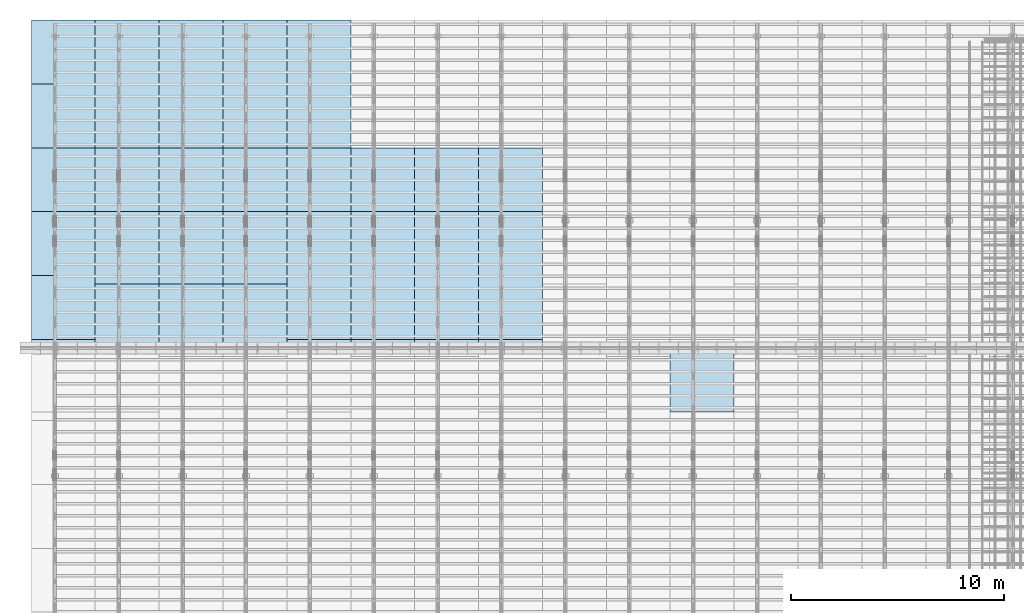
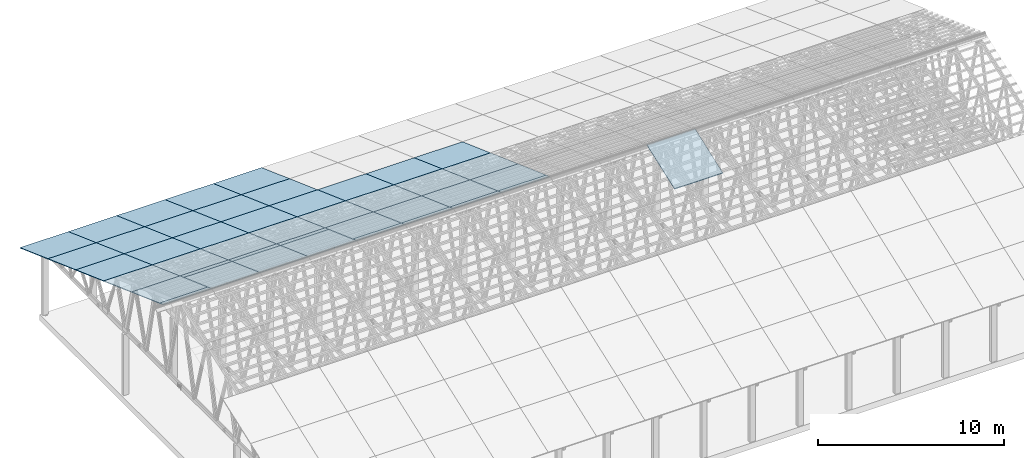
# One storey, part 7 of 189: 43 slabs, 43 elements without a shape of their own.
"""IFC2X3 building model written with IfcOpenShell, lengths in millimetres."""

from ifc_helpers import new_model, entity, si_unit, converted_unit, derived_unit, direction, frame, frame_2d, origin, place, context, subcontext, project, spatial, rectangle, extrude, material, layer, layer_set, element, aggregate, save


model = new_model("IFC2X3")

# Units and contexts
model_context = context("Model", 3, precision=0.01, world=origin(), true_north=direction((6.12303176911189e-17, 1.0)))
body_context = subcontext(model_context, "Body", "Model", "MODEL_VIEW")
ifc_project = project(units=[si_unit("LENGTHUNIT", "METRE", prefix="MILLI"), si_unit("AREAUNIT", "SQUARE_METRE"), si_unit("VOLUMEUNIT", "CUBIC_METRE"), converted_unit("PLANEANGLEUNIT", "DEGREE", entity("IfcRatioMeasure", 0.0174532925199433), si_unit("PLANEANGLEUNIT", "RADIAN"), dimensions=[0, 0, 0, 0, 0, 0, 0]), si_unit("MASSUNIT", "GRAM", prefix="KILO"), derived_unit("MASSDENSITYUNIT", [(si_unit("MASSUNIT", "GRAM", prefix="KILO"), 1), (si_unit("LENGTHUNIT", "METRE"), -3)]), si_unit("TIMEUNIT", "SECOND"), si_unit("FREQUENCYUNIT", "HERTZ"), si_unit("THERMODYNAMICTEMPERATUREUNIT", "DEGREE_CELSIUS"), derived_unit("THERMALTRANSMITTANCEUNIT", [(si_unit("MASSUNIT", "GRAM", prefix="KILO"), 1), (si_unit("THERMODYNAMICTEMPERATUREUNIT", "KELVIN"), -1), (si_unit("TIMEUNIT", "SECOND"), -3)]), derived_unit("VOLUMETRICFLOWRATEUNIT", [(si_unit("LENGTHUNIT", "METRE"), 3), (si_unit("TIMEUNIT", "SECOND"), -1)]), si_unit("ELECTRICCURRENTUNIT", "AMPERE"), si_unit("ELECTRICVOLTAGEUNIT", "VOLT"), si_unit("POWERUNIT", "WATT"), si_unit("FORCEUNIT", "NEWTON"), si_unit("ILLUMINANCEUNIT", "LUX"), si_unit("LUMINOUSFLUXUNIT", "LUMEN"), si_unit("LUMINOUSINTENSITYUNIT", "CANDELA"), derived_unit("USERDEFINED", [(si_unit("MASSUNIT", "GRAM", prefix="KILO"), -1), (si_unit("LENGTHUNIT", "METRE"), -2), (si_unit("TIMEUNIT", "SECOND"), 3), (si_unit("LUMINOUSFLUXUNIT", "LUMEN"), 1)]), derived_unit("LINEARVELOCITYUNIT", [(si_unit("LENGTHUNIT", "METRE"), 1), (si_unit("TIMEUNIT", "SECOND"), -1)]), si_unit("PRESSUREUNIT", "PASCAL"), derived_unit("USERDEFINED", [(si_unit("LENGTHUNIT", "METRE"), -2), (si_unit("MASSUNIT", "GRAM", prefix="KILO"), 1), (si_unit("TIMEUNIT", "SECOND"), -2)])], contexts=[model_context])

# Site, building, storey
site_placement = place(None, origin())
site = spatial("IfcSite", under=ifc_project, at=site_placement, CompositionType="ELEMENT")
building_placement = place(site_placement, origin())
building = spatial("IfcBuilding", under=site, at=building_placement, CompositionType="ELEMENT")
storey_placement = place(building_placement, origin())
storey = spatial("IfcBuildingStorey", under=building, at=storey_placement, Name="Default", CompositionType="ELEMENT", Elevation=0.0)

# Roof, slab
roof_1_placement = place(storey_placement, frame((29153.4200853156, 11750.0000438631, 4752.15507836903)))
roof_1 = element("IfcRoof", 1, at=roof_1_placement, inside=storey, ShapeType="NOTDEFINED")
ifc_material = material()
ifc_layer = layer(ifc_material, 40.0)
ifc_layer_set = layer_set([ifc_layer])
slab_1_placement = place(roof_1_placement, origin())
slab_1 = element("IfcSlab", 2, at=slab_1_placement, material=ifc_layer_set, PredefinedType="ROOF", context=body_context, shape_type="SweptSolid", body=[
    extrude(rectangle(XDim=3192.53331742773, YDim=2999.99999999999, at=frame_2d((0.0, 0.0), x_axis=(0.0, -1.0))), frame((1500.0, 1500.0, 545.955351399303), z_axis=(0.0, -0.342020143325669, 0.939692620785908), x_axis=(1.0, 0.0, 0.0)), (0.0, 0.342020143325669, 0.939692620785908), 42.5671108990361),
])
aggregate(roof_1, [slab_1])

roof_2_placement = place(storey_placement, frame((20153.4200853157, 21152.222636977, 2421.93662132902)))
roof_2 = element("IfcRoof", 3, at=roof_2_placement, inside=storey, ShapeType="NOTDEFINED")
slab_2_placement = place(roof_2_placement, origin())
slab_2 = element("IfcSlab", 4, at=slab_2_placement, material=ifc_layer_set, PredefinedType="ROOF", context=body_context, shape_type="SweptSolid", body=[
    extrude(rectangle(XDim=3192.53331742773, YDim=3000.0, at=frame_2d((2.1600499167107e-12, 1.13686837721616e-13), x_axis=(0.0, 1.0))), frame((1500.0, 1500.0, 545.955351399304), z_axis=(0.0, 0.342020143325669, 0.939692620785908), x_axis=(1.0, 0.0, 0.0)), (0.0, -0.342020143325669, 0.939692620785908), 42.5671108990361),
])
aggregate(roof_2, [slab_2])

roof_3_placement = place(storey_placement, frame((20153.4200853157, 18152.222636977, 3513.84732412761)))
roof_3 = element("IfcRoof", 5, at=roof_3_placement, inside=storey, ShapeType="NOTDEFINED")
slab_3_placement = place(roof_3_placement, origin())
slab_3 = element("IfcSlab", 6, at=slab_3_placement, material=ifc_layer_set, PredefinedType="ROOF", context=body_context, shape_type="SweptSolid", body=[
    extrude(rectangle(XDim=3192.53331742773, YDim=3000.0, at=frame_2d((2.1600499167107e-12, 0.0), x_axis=(0.0, 1.0))), frame((1500.0, 1500.0, 545.955351399303), z_axis=(0.0, 0.342020143325669, 0.939692620785908), x_axis=(1.0, 0.0, 0.0)), (0.0, -0.342020143325669, 0.939692620785908), 42.5671108990366),
])
aggregate(roof_3, [slab_3])

roof_4_placement = place(storey_placement, frame((20153.4200853157, 15152.222636977, 4605.75802692621)))
roof_4 = element("IfcRoof", 7, at=roof_4_placement, inside=storey, ShapeType="NOTDEFINED")
slab_4_placement = place(roof_4_placement, origin())
slab_4 = element("IfcSlab", 8, at=slab_4_placement, material=ifc_layer_set, PredefinedType="ROOF", context=body_context, shape_type="SweptSolid", body=[
    extrude(rectangle(XDim=3192.53331742773, YDim=3000.0, at=frame_2d((2.1600499167107e-12, -1.13686837721616e-13), x_axis=(0.0, 1.0))), frame((1500.0, 1500.0, 545.955351399304), z_axis=(0.0, 0.342020143325669, 0.939692620785908), x_axis=(1.0, 0.0, 0.0)), (0.0, -0.342020143325669, 0.939692620785908), 42.5671108990361),
])
aggregate(roof_4, [slab_4])

roof_5_placement = place(storey_placement, frame((20153.4200853157, 14750.0000438631, 4752.15507836903)))
roof_5 = element("IfcRoof", 9, at=roof_5_placement, inside=storey, ShapeType="NOTDEFINED")
slab_5_placement = place(roof_5_placement, origin())
slab_5 = element("IfcSlab", 10, at=slab_5_placement, material=ifc_layer_set, PredefinedType="ROOF", context=body_context, shape_type="SweptSolid", body=[
    extrude(rectangle(XDim=3192.53331742773, YDim=3000.0, at=frame_2d((2.1600499167107e-12, -1.13686837721616e-13), x_axis=(0.0, 1.0))), frame((1500.0, 1500.0, 545.955351399304), z_axis=(0.0, 0.342020143325669, 0.939692620785908), x_axis=(1.0, 0.0, 0.0)), (0.0, -0.342020143325669, 0.939692620785908), 42.5671108990361),
])
aggregate(roof_5, [slab_5])

roof_6_placement = place(storey_placement, frame((17153.4200853157, 21152.222636977, 2421.93662132902)))
roof_6 = element("IfcRoof", 11, at=roof_6_placement, inside=storey, ShapeType="NOTDEFINED")
slab_6_placement = place(roof_6_placement, origin())
slab_6 = element("IfcSlab", 12, at=slab_6_placement, material=ifc_layer_set, PredefinedType="ROOF", context=body_context, shape_type="SweptSolid", body=[
    extrude(rectangle(XDim=3192.53331742773, YDim=3000.0, at=frame_2d((0.0, 1.13686837721616e-13), x_axis=(0.0, 1.0))), frame((1500.0, 1500.0, 545.955351399304), z_axis=(0.0, 0.342020143325669, 0.939692620785908), x_axis=(1.0, 0.0, 0.0)), (0.0, -0.342020143325669, 0.939692620785908), 42.5671108990361),
])
aggregate(roof_6, [slab_6])

roof_7_placement = place(storey_placement, frame((17153.4200853157, 18152.222636977, 3513.84732412761)))
roof_7 = element("IfcRoof", 13, at=roof_7_placement, inside=storey, ShapeType="NOTDEFINED")
slab_7_placement = place(roof_7_placement, origin())
slab_7 = element("IfcSlab", 14, at=slab_7_placement, material=ifc_layer_set, PredefinedType="ROOF", context=body_context, shape_type="SweptSolid", body=[
    extrude(rectangle(XDim=3192.53331742773, YDim=3000.0, at=frame_2d((0.0, 0.0), x_axis=(0.0, 1.0))), frame((1500.0, 1500.0, 545.955351399303), z_axis=(0.0, 0.342020143325669, 0.939692620785908), x_axis=(1.0, 0.0, 0.0)), (0.0, -0.342020143325669, 0.939692620785908), 42.5671108990366),
])
aggregate(roof_7, [slab_7])

roof_8_placement = place(storey_placement, frame((17153.4200853157, 15152.222636977, 4605.75802692621)))
roof_8 = element("IfcRoof", 15, at=roof_8_placement, inside=storey, ShapeType="NOTDEFINED")
slab_8_placement = place(roof_8_placement, origin())
slab_8 = element("IfcSlab", 16, at=slab_8_placement, material=ifc_layer_set, PredefinedType="ROOF", context=body_context, shape_type="SweptSolid", body=[
    extrude(rectangle(XDim=3192.53331742773, YDim=3000.0, at=frame_2d((0.0, -1.13686837721616e-13), x_axis=(0.0, 1.0))), frame((1500.0, 1500.0, 545.955351399304), z_axis=(0.0, 0.342020143325669, 0.939692620785908), x_axis=(1.0, 0.0, 0.0)), (0.0, -0.342020143325669, 0.939692620785908), 42.5671108990361),
])
aggregate(roof_8, [slab_8])

roof_9_placement = place(storey_placement, frame((17153.4200853157, 14750.0000438631, 4752.15507836903)))
roof_9 = element("IfcRoof", 17, at=roof_9_placement, inside=storey, ShapeType="NOTDEFINED")
slab_9_placement = place(roof_9_placement, origin())
slab_9 = element("IfcSlab", 18, at=slab_9_placement, material=ifc_layer_set, PredefinedType="ROOF", context=body_context, shape_type="SweptSolid", body=[
    extrude(rectangle(XDim=3192.53331742773, YDim=3000.0, at=frame_2d((0.0, -1.13686837721616e-13), x_axis=(0.0, 1.0))), frame((1500.0, 1500.0, 545.955351399304), z_axis=(0.0, 0.342020143325669, 0.939692620785908), x_axis=(1.0, 0.0, 0.0)), (0.0, -0.342020143325669, 0.939692620785908), 42.5671108990361),
])
aggregate(roof_9, [slab_9])

roof_10_placement = place(storey_placement, frame((14153.4200853157, 21152.2226369771, 2421.93662132902)))
roof_10 = element("IfcRoof", 19, at=roof_10_placement, inside=storey, ShapeType="NOTDEFINED")
slab_10_placement = place(roof_10_placement, origin())
slab_10 = element("IfcSlab", 20, at=slab_10_placement, material=ifc_layer_set, PredefinedType="ROOF", context=body_context, shape_type="SweptSolid", body=[
    extrude(rectangle(XDim=3192.53331742773, YDim=3000.0, at=frame_2d((0.0, 1.13686837721616e-13), x_axis=(0.0, 1.0))), frame((1500.0, 1500.0, 545.955351399304), z_axis=(0.0, 0.342020143325669, 0.939692620785908), x_axis=(1.0, 0.0, 0.0)), (0.0, -0.342020143325669, 0.939692620785908), 42.5671108990361),
])
aggregate(roof_10, [slab_10])

roof_11_placement = place(storey_placement, frame((14153.4200853157, 18152.222636977, 3513.84732412761)))
roof_11 = element("IfcRoof", 21, at=roof_11_placement, inside=storey, ShapeType="NOTDEFINED")
slab_11_placement = place(roof_11_placement, origin())
slab_11 = element("IfcSlab", 22, at=slab_11_placement, material=ifc_layer_set, PredefinedType="ROOF", context=body_context, shape_type="SweptSolid", body=[
    extrude(rectangle(XDim=3192.53331742773, YDim=3000.0, at=frame_2d((0.0, 0.0), x_axis=(0.0, 1.0))), frame((1500.0, 1500.0, 545.955351399303), z_axis=(0.0, 0.342020143325669, 0.939692620785908), x_axis=(1.0, 0.0, 0.0)), (0.0, -0.342020143325669, 0.939692620785908), 42.5671108990366),
])
aggregate(roof_11, [slab_11])

roof_12_placement = place(storey_placement, frame((14153.4200853157, 15152.222636977, 4605.75802692621)))
roof_12 = element("IfcRoof", 23, at=roof_12_placement, inside=storey, ShapeType="NOTDEFINED")
slab_12_placement = place(roof_12_placement, origin())
slab_12 = element("IfcSlab", 24, at=slab_12_placement, material=ifc_layer_set, PredefinedType="ROOF", context=body_context, shape_type="SweptSolid", body=[
    extrude(rectangle(XDim=3192.53331742773, YDim=3000.0, at=frame_2d((0.0, -1.13686837721616e-13), x_axis=(0.0, 1.0))), frame((1500.0, 1500.0, 545.955351399304), z_axis=(0.0, 0.342020143325669, 0.939692620785908), x_axis=(1.0, 0.0, 0.0)), (0.0, -0.342020143325669, 0.939692620785908), 42.5671108990361),
])
aggregate(roof_12, [slab_12])

roof_13_placement = place(storey_placement, frame((14153.4200853157, 14750.0000438632, 4752.15507836903)))
roof_13 = element("IfcRoof", 25, at=roof_13_placement, inside=storey, ShapeType="NOTDEFINED")
slab_13_placement = place(roof_13_placement, origin())
slab_13 = element("IfcSlab", 26, at=slab_13_placement, material=ifc_layer_set, PredefinedType="ROOF", context=body_context, shape_type="SweptSolid", body=[
    extrude(rectangle(XDim=3192.53331742773, YDim=3000.0, at=frame_2d((0.0, -1.13686837721616e-13), x_axis=(0.0, 1.0))), frame((1500.0, 1500.0, 545.955351399304), z_axis=(0.0, 0.342020143325669, 0.939692620785908), x_axis=(1.0, 0.0, 0.0)), (0.0, -0.342020143325669, 0.939692620785908), 42.5671108990361),
])
aggregate(roof_13, [slab_13])

roof_14_placement = place(storey_placement, frame((11153.4200853158, 27152.2226369771, 238.115215731819)))
roof_14 = element("IfcRoof", 27, at=roof_14_placement, inside=storey, ShapeType="NOTDEFINED")
slab_14_placement = place(roof_14_placement, origin())
slab_14 = element("IfcSlab", 28, at=slab_14_placement, material=ifc_layer_set, PredefinedType="ROOF", context=body_context, shape_type="SweptSolid", body=[
    extrude(rectangle(XDim=3192.53331742773, YDim=2999.99999999999, at=frame_2d((0.0, 1.13686837721616e-13), x_axis=(0.0, 1.0))), frame((1500.0, 1500.0, 545.955351399304), z_axis=(0.0, 0.342020143325669, 0.939692620785908), x_axis=(1.0, 0.0, 0.0)), (0.0, -0.342020143325669, 0.939692620785908), 42.5671108990364),
])
aggregate(roof_14, [slab_14])

roof_15_placement = place(storey_placement, frame((11153.4200853157, 24152.2226369771, 1330.02591853042)))
roof_15 = element("IfcRoof", 29, at=roof_15_placement, inside=storey, ShapeType="NOTDEFINED")
slab_15_placement = place(roof_15_placement, origin())
slab_15 = element("IfcSlab", 30, at=slab_15_placement, material=ifc_layer_set, PredefinedType="ROOF", context=body_context, shape_type="SweptSolid", body=[
    extrude(rectangle(XDim=3192.53331742773, YDim=2999.99999999999, at=frame_2d((0.0, 0.0), x_axis=(0.0, 1.0))), frame((1500.0, 1500.0, 545.955351399304), z_axis=(0.0, 0.342020143325669, 0.939692620785908), x_axis=(1.0, 0.0, 0.0)), (0.0, -0.342020143325669, 0.939692620785908), 42.5671108990358),
])
aggregate(roof_15, [slab_15])

roof_16_placement = place(storey_placement, frame((11153.4200853158, 21152.2226369771, 2421.93662132902)))
roof_16 = element("IfcRoof", 31, at=roof_16_placement, inside=storey, ShapeType="NOTDEFINED")
slab_16_placement = place(roof_16_placement, origin())
slab_16 = element("IfcSlab", 32, at=slab_16_placement, material=ifc_layer_set, PredefinedType="ROOF", context=body_context, shape_type="SweptSolid", body=[
    extrude(rectangle(XDim=3192.53331742773, YDim=3000.0, at=frame_2d((0.0, 1.13686837721616e-13), x_axis=(0.0, 1.0))), frame((1500.0, 1500.0, 545.955351399304), z_axis=(0.0, 0.342020143325669, 0.939692620785908), x_axis=(1.0, 0.0, 0.0)), (0.0, -0.342020143325669, 0.939692620785908), 42.5671108990361),
])
aggregate(roof_16, [slab_16])

roof_17_placement = place(storey_placement, frame((11153.4200853158, 18152.2226369771, 3513.84732412761)))
roof_17 = element("IfcRoof", 33, at=roof_17_placement, inside=storey, ShapeType="NOTDEFINED")
slab_17_placement = place(roof_17_placement, origin())
slab_17 = element("IfcSlab", 34, at=slab_17_placement, material=ifc_layer_set, PredefinedType="ROOF", context=body_context, shape_type="SweptSolid", body=[
    extrude(rectangle(XDim=3192.53331742773, YDim=3000.0, at=frame_2d((0.0, 0.0), x_axis=(0.0, 1.0))), frame((1500.0, 1500.0, 545.955351399303), z_axis=(0.0, 0.342020143325669, 0.939692620785908), x_axis=(1.0, 0.0, 0.0)), (0.0, -0.342020143325669, 0.939692620785908), 42.5671108990366),
])
aggregate(roof_17, [slab_17])

roof_18_placement = place(storey_placement, frame((11153.4200853158, 15152.2226369771, 4605.75802692621)))
roof_18 = element("IfcRoof", 35, at=roof_18_placement, inside=storey, ShapeType="NOTDEFINED")
slab_18_placement = place(roof_18_placement, origin())
slab_18 = element("IfcSlab", 36, at=slab_18_placement, material=ifc_layer_set, PredefinedType="ROOF", context=body_context, shape_type="SweptSolid", body=[
    extrude(rectangle(XDim=3192.53331742773, YDim=3000.0, at=frame_2d((0.0, -1.13686837721616e-13), x_axis=(0.0, 1.0))), frame((1500.0, 1500.0, 545.955351399304), z_axis=(0.0, 0.342020143325669, 0.939692620785908), x_axis=(1.0, 0.0, 0.0)), (0.0, -0.342020143325669, 0.939692620785908), 42.5671108990361),
])
aggregate(roof_18, [slab_18])

roof_19_placement = place(storey_placement, frame((11153.4200853158, 14750.0000438632, 4752.15507836903)))
roof_19 = element("IfcRoof", 37, at=roof_19_placement, inside=storey, ShapeType="NOTDEFINED")
slab_19_placement = place(roof_19_placement, origin())
slab_19 = element("IfcSlab", 38, at=slab_19_placement, material=ifc_layer_set, PredefinedType="ROOF", context=body_context, shape_type="SweptSolid", body=[
    extrude(rectangle(XDim=3192.53331742773, YDim=3000.0, at=frame_2d((0.0, -1.13686837721616e-13), x_axis=(0.0, 1.0))), frame((1500.0, 1500.0, 545.955351399304), z_axis=(0.0, 0.342020143325669, 0.939692620785908), x_axis=(1.0, 0.0, 0.0)), (0.0, -0.342020143325669, 0.939692620785908), 42.5671108990361),
])
aggregate(roof_19, [slab_19])

roof_20_placement = place(storey_placement, frame((8153.42008531579, 27152.2226369771, 238.115215731819)))
roof_20 = element("IfcRoof", 39, at=roof_20_placement, inside=storey, ShapeType="NOTDEFINED")
slab_20_placement = place(roof_20_placement, origin())
slab_20 = element("IfcSlab", 40, at=slab_20_placement, material=ifc_layer_set, PredefinedType="ROOF", context=body_context, shape_type="SweptSolid", body=[
    extrude(rectangle(XDim=3192.53331742773, YDim=2999.99999999999, at=frame_2d((5.6843418860808e-13, 1.13686837721616e-13), x_axis=(0.0, 1.0))), frame((1500.0, 1500.0, 545.955351399304), z_axis=(0.0, 0.342020143325669, 0.939692620785908), x_axis=(1.0, 0.0, 0.0)), (0.0, -0.342020143325669, 0.939692620785908), 42.5671108990364),
])
aggregate(roof_20, [slab_20])

roof_21_placement = place(storey_placement, frame((8153.42008531577, 24152.2226369771, 1330.02591853042)))
roof_21 = element("IfcRoof", 41, at=roof_21_placement, inside=storey, ShapeType="NOTDEFINED")
slab_21_placement = place(roof_21_placement, origin())
slab_21 = element("IfcSlab", 42, at=slab_21_placement, material=ifc_layer_set, PredefinedType="ROOF", context=body_context, shape_type="SweptSolid", body=[
    extrude(rectangle(XDim=3192.53331742773, YDim=2999.99999999999, at=frame_2d((5.6843418860808e-13, 0.0), x_axis=(0.0, 1.0))), frame((1500.0, 1500.0, 545.955351399304), z_axis=(0.0, 0.342020143325669, 0.939692620785908), x_axis=(1.0, 0.0, 0.0)), (0.0, -0.342020143325669, 0.939692620785908), 42.5671108990358),
])
aggregate(roof_21, [slab_21])

roof_22_placement = place(storey_placement, frame((8153.42008531578, 21152.2226369771, 2421.93662132902)))
roof_22 = element("IfcRoof", 43, at=roof_22_placement, inside=storey, ShapeType="NOTDEFINED")
slab_22_placement = place(roof_22_placement, origin())
slab_22 = element("IfcSlab", 44, at=slab_22_placement, material=ifc_layer_set, PredefinedType="ROOF", context=body_context, shape_type="SweptSolid", body=[
    extrude(rectangle(XDim=3192.53331742773, YDim=3000.0, at=frame_2d((5.6843418860808e-13, 1.13686837721616e-13), x_axis=(0.0, 1.0))), frame((1500.0, 1500.0, 545.955351399304), z_axis=(0.0, 0.342020143325669, 0.939692620785908), x_axis=(1.0, 0.0, 0.0)), (0.0, -0.342020143325669, 0.939692620785908), 42.5671108990361),
])
aggregate(roof_22, [slab_22])

roof_23_placement = place(storey_placement, frame((8153.42008531577, 18152.2226369771, 3513.84732412761)))
roof_23 = element("IfcRoof", 45, at=roof_23_placement, inside=storey, ShapeType="NOTDEFINED")
slab_23_placement = place(roof_23_placement, origin())
slab_23 = element("IfcSlab", 46, at=slab_23_placement, material=ifc_layer_set, PredefinedType="ROOF", context=body_context, shape_type="SweptSolid", body=[
    extrude(rectangle(XDim=3192.53331742773, YDim=3000.0, at=frame_2d((5.6843418860808e-13, 0.0), x_axis=(0.0, 1.0))), frame((1500.0, 1500.0, 545.955351399303), z_axis=(0.0, 0.342020143325669, 0.939692620785908), x_axis=(1.0, 0.0, 0.0)), (0.0, -0.342020143325669, 0.939692620785908), 42.5671108990366),
])
aggregate(roof_23, [slab_23])

roof_24_placement = place(storey_placement, frame((8153.42008531578, 15152.2226369771, 4605.75802692621)))
roof_24 = element("IfcRoof", 47, at=roof_24_placement, inside=storey, ShapeType="NOTDEFINED")
slab_24_placement = place(roof_24_placement, origin())
slab_24 = element("IfcSlab", 48, at=slab_24_placement, material=ifc_layer_set, PredefinedType="ROOF", context=body_context, shape_type="SweptSolid", body=[
    extrude(rectangle(XDim=3192.53331742773, YDim=3000.0, at=frame_2d((5.6843418860808e-13, -1.13686837721616e-13), x_axis=(0.0, 1.0))), frame((1500.0, 1500.0, 545.955351399304), z_axis=(0.0, 0.342020143325669, 0.939692620785908), x_axis=(1.0, 0.0, 0.0)), (0.0, -0.342020143325669, 0.939692620785908), 42.5671108990361),
])
aggregate(roof_24, [slab_24])

roof_25_placement = place(storey_placement, frame((8153.42008531578, 14750.0000438632, 4752.15507836903)))
roof_25 = element("IfcRoof", 49, at=roof_25_placement, inside=storey, ShapeType="NOTDEFINED")
slab_25_placement = place(roof_25_placement, origin())
slab_25 = element("IfcSlab", 50, at=slab_25_placement, material=ifc_layer_set, PredefinedType="ROOF", context=body_context, shape_type="SweptSolid", body=[
    extrude(rectangle(XDim=3192.53331742773, YDim=3000.0, at=frame_2d((5.6843418860808e-13, -1.13686837721616e-13), x_axis=(0.0, 1.0))), frame((1500.0, 1500.0, 545.955351399304), z_axis=(0.0, 0.342020143325669, 0.939692620785908), x_axis=(1.0, 0.0, 0.0)), (0.0, -0.342020143325669, 0.939692620785908), 42.5671108990361),
])
aggregate(roof_25, [slab_25])

roof_26_placement = place(storey_placement, frame((5153.42008531581, 27152.2226369771, 238.115215731819)))
roof_26 = element("IfcRoof", 51, at=roof_26_placement, inside=storey, ShapeType="NOTDEFINED")
slab_26_placement = place(roof_26_placement, origin())
slab_26 = element("IfcSlab", 52, at=slab_26_placement, material=ifc_layer_set, PredefinedType="ROOF", context=body_context, shape_type="SweptSolid", body=[
    extrude(rectangle(XDim=3192.53331742773, YDim=2999.99999999999, at=frame_2d((5.6843418860808e-13, 1.13686837721616e-13), x_axis=(0.0, 1.0))), frame((1500.0, 1500.0, 545.955351399304), z_axis=(0.0, 0.342020143325669, 0.939692620785908), x_axis=(1.0, 0.0, 0.0)), (0.0, -0.342020143325669, 0.939692620785908), 42.5671108990364),
])
aggregate(roof_26, [slab_26])

roof_27_placement = place(storey_placement, frame((5153.42008531579, 24152.2226369771, 1330.02591853042)))
roof_27 = element("IfcRoof", 53, at=roof_27_placement, inside=storey, ShapeType="NOTDEFINED")
slab_27_placement = place(roof_27_placement, origin())
slab_27 = element("IfcSlab", 54, at=slab_27_placement, material=ifc_layer_set, PredefinedType="ROOF", context=body_context, shape_type="SweptSolid", body=[
    extrude(rectangle(XDim=3192.53331742773, YDim=2999.99999999999, at=frame_2d((5.6843418860808e-13, 0.0), x_axis=(0.0, 1.0))), frame((1500.0, 1500.0, 545.955351399304), z_axis=(0.0, 0.342020143325669, 0.939692620785908), x_axis=(1.0, 0.0, 0.0)), (0.0, -0.342020143325669, 0.939692620785908), 42.5671108990358),
])
aggregate(roof_27, [slab_27])

roof_28_placement = place(storey_placement, frame((5153.42008531581, 21152.2226369771, 2421.93662132902)))
roof_28 = element("IfcRoof", 55, at=roof_28_placement, inside=storey, ShapeType="NOTDEFINED")
slab_28_placement = place(roof_28_placement, origin())
slab_28 = element("IfcSlab", 56, at=slab_28_placement, material=ifc_layer_set, PredefinedType="ROOF", context=body_context, shape_type="SweptSolid", body=[
    extrude(rectangle(XDim=3192.53331742773, YDim=3000.0, at=frame_2d((5.6843418860808e-13, 1.13686837721616e-13), x_axis=(0.0, 1.0))), frame((1500.0, 1500.0, 545.955351399304), z_axis=(0.0, 0.342020143325669, 0.939692620785908), x_axis=(1.0, 0.0, 0.0)), (0.0, -0.342020143325669, 0.939692620785908), 42.5671108990361),
])
aggregate(roof_28, [slab_28])

roof_29_placement = place(storey_placement, frame((5153.4200853158, 18152.2226369771, 3513.84732412761)))
roof_29 = element("IfcRoof", 57, at=roof_29_placement, inside=storey, ShapeType="NOTDEFINED")
slab_29_placement = place(roof_29_placement, origin())
slab_29 = element("IfcSlab", 58, at=slab_29_placement, material=ifc_layer_set, PredefinedType="ROOF", context=body_context, shape_type="SweptSolid", body=[
    extrude(rectangle(XDim=3192.53331742773, YDim=3000.0, at=frame_2d((5.6843418860808e-13, 0.0), x_axis=(0.0, 1.0))), frame((1500.0, 1500.0, 545.955351399303), z_axis=(0.0, 0.342020143325669, 0.939692620785908), x_axis=(1.0, 0.0, 0.0)), (0.0, -0.342020143325669, 0.939692620785908), 42.5671108990366),
])
aggregate(roof_29, [slab_29])

roof_30_placement = place(storey_placement, frame((5153.42008531581, 15152.2226369771, 4605.75802692621)))
roof_30 = element("IfcRoof", 59, at=roof_30_placement, inside=storey, ShapeType="NOTDEFINED")
slab_30_placement = place(roof_30_placement, origin())
slab_30 = element("IfcSlab", 60, at=slab_30_placement, material=ifc_layer_set, PredefinedType="ROOF", context=body_context, shape_type="SweptSolid", body=[
    extrude(rectangle(XDim=3192.53331742773, YDim=3000.0, at=frame_2d((5.6843418860808e-13, -1.13686837721616e-13), x_axis=(0.0, 1.0))), frame((1500.0, 1500.0, 545.955351399304), z_axis=(0.0, 0.342020143325669, 0.939692620785908), x_axis=(1.0, 0.0, 0.0)), (0.0, -0.342020143325669, 0.939692620785908), 42.5671108990361),
])
aggregate(roof_30, [slab_30])

roof_31_placement = place(storey_placement, frame((5153.42008531581, 14750.0000438632, 4752.15507836903)))
roof_31 = element("IfcRoof", 61, at=roof_31_placement, inside=storey, ShapeType="NOTDEFINED")
slab_31_placement = place(roof_31_placement, origin())
slab_31 = element("IfcSlab", 62, at=slab_31_placement, material=ifc_layer_set, PredefinedType="ROOF", context=body_context, shape_type="SweptSolid", body=[
    extrude(rectangle(XDim=3192.53331742773, YDim=3000.0, at=frame_2d((5.6843418860808e-13, -1.13686837721616e-13), x_axis=(0.0, 1.0))), frame((1500.0, 1500.0, 545.955351399304), z_axis=(0.0, 0.342020143325669, 0.939692620785908), x_axis=(1.0, 0.0, 0.0)), (0.0, -0.342020143325669, 0.939692620785908), 42.5671108990361),
])
aggregate(roof_31, [slab_31])

roof_32_placement = place(storey_placement, frame((2153.42008531584, 27152.2226369771, 238.115215731819)))
roof_32 = element("IfcRoof", 63, at=roof_32_placement, inside=storey, ShapeType="NOTDEFINED")
slab_32_placement = place(roof_32_placement, origin())
slab_32 = element("IfcSlab", 64, at=slab_32_placement, material=ifc_layer_set, PredefinedType="ROOF", context=body_context, shape_type="SweptSolid", body=[
    extrude(rectangle(XDim=3192.53331742773, YDim=2999.99999999999, at=frame_2d((5.6843418860808e-13, 1.13686837721616e-13), x_axis=(0.0, 1.0))), frame((1500.0, 1500.0, 545.955351399304), z_axis=(0.0, 0.342020143325669, 0.939692620785908), x_axis=(1.0, 0.0, 0.0)), (0.0, -0.342020143325669, 0.939692620785908), 42.5671108990364),
])
aggregate(roof_32, [slab_32])

roof_33_placement = place(storey_placement, frame((2153.42008531581, 24152.2226369771, 1330.02591853042)))
roof_33 = element("IfcRoof", 65, at=roof_33_placement, inside=storey, ShapeType="NOTDEFINED")
slab_33_placement = place(roof_33_placement, origin())
slab_33 = element("IfcSlab", 66, at=slab_33_placement, material=ifc_layer_set, PredefinedType="ROOF", context=body_context, shape_type="SweptSolid", body=[
    extrude(rectangle(XDim=3192.53331742773, YDim=2999.99999999999, at=frame_2d((5.6843418860808e-13, 0.0), x_axis=(0.0, 1.0))), frame((1500.0, 1500.0, 545.955351399304), z_axis=(0.0, 0.342020143325669, 0.939692620785908), x_axis=(1.0, 0.0, 0.0)), (0.0, -0.342020143325669, 0.939692620785908), 42.5671108990358),
])
aggregate(roof_33, [slab_33])

roof_34_placement = place(storey_placement, frame((2153.42008531583, 21152.2226369771, 2421.93662132902)))
roof_34 = element("IfcRoof", 67, at=roof_34_placement, inside=storey, ShapeType="NOTDEFINED")
slab_34_placement = place(roof_34_placement, origin())
slab_34 = element("IfcSlab", 68, at=slab_34_placement, material=ifc_layer_set, PredefinedType="ROOF", context=body_context, shape_type="SweptSolid", body=[
    extrude(rectangle(XDim=3192.53331742773, YDim=3000.0, at=frame_2d((5.6843418860808e-13, 1.13686837721616e-13), x_axis=(0.0, 1.0))), frame((1500.0, 1500.0, 545.955351399304), z_axis=(0.0, 0.342020143325669, 0.939692620785908), x_axis=(1.0, 0.0, 0.0)), (0.0, -0.342020143325669, 0.939692620785908), 42.5671108990361),
])
aggregate(roof_34, [slab_34])

roof_35_placement = place(storey_placement, frame((2153.42008531582, 18152.2226369771, 3513.84732412761)))
roof_35 = element("IfcRoof", 69, at=roof_35_placement, inside=storey, ShapeType="NOTDEFINED")
slab_35_placement = place(roof_35_placement, origin())
slab_35 = element("IfcSlab", 70, at=slab_35_placement, material=ifc_layer_set, PredefinedType="ROOF", context=body_context, shape_type="SweptSolid", body=[
    extrude(rectangle(XDim=3192.53331742773, YDim=3000.0, at=frame_2d((5.6843418860808e-13, 0.0), x_axis=(0.0, 1.0))), frame((1500.0, 1500.0, 545.955351399303), z_axis=(0.0, 0.342020143325669, 0.939692620785908), x_axis=(1.0, 0.0, 0.0)), (0.0, -0.342020143325669, 0.939692620785908), 42.5671108990366),
])
aggregate(roof_35, [slab_35])

roof_36_placement = place(storey_placement, frame((2153.42008531583, 15152.2226369771, 4605.75802692621)))
roof_36 = element("IfcRoof", 71, at=roof_36_placement, inside=storey, ShapeType="NOTDEFINED")
slab_36_placement = place(roof_36_placement, origin())
slab_36 = element("IfcSlab", 72, at=slab_36_placement, material=ifc_layer_set, PredefinedType="ROOF", context=body_context, shape_type="SweptSolid", body=[
    extrude(rectangle(XDim=3192.53331742773, YDim=3000.0, at=frame_2d((5.6843418860808e-13, -1.13686837721616e-13), x_axis=(0.0, 1.0))), frame((1500.0, 1500.0, 545.955351399304), z_axis=(0.0, 0.342020143325669, 0.939692620785908), x_axis=(1.0, 0.0, 0.0)), (0.0, -0.342020143325669, 0.939692620785908), 42.5671108990361),
])
aggregate(roof_36, [slab_36])

roof_37_placement = place(storey_placement, frame((2153.42008531583, 14750.0000438632, 4752.15507836903)))
roof_37 = element("IfcRoof", 73, at=roof_37_placement, inside=storey, ShapeType="NOTDEFINED")
slab_37_placement = place(roof_37_placement, origin())
slab_37 = element("IfcSlab", 74, at=slab_37_placement, material=ifc_layer_set, PredefinedType="ROOF", context=body_context, shape_type="SweptSolid", body=[
    extrude(rectangle(XDim=3192.53331742773, YDim=3000.0, at=frame_2d((5.6843418860808e-13, -1.13686837721616e-13), x_axis=(0.0, 1.0))), frame((1500.0, 1500.0, 545.955351399304), z_axis=(0.0, 0.342020143325669, 0.939692620785908), x_axis=(1.0, 0.0, 0.0)), (0.0, -0.342020143325669, 0.939692620785908), 42.5671108990361),
])
aggregate(roof_37, [slab_37])

roof_38_placement = place(storey_placement, frame((-846.579914684138, 27152.2226369771, 238.115215731819)))
roof_38 = element("IfcRoof", 75, at=roof_38_placement, inside=storey, ShapeType="NOTDEFINED")
slab_38_placement = place(roof_38_placement, origin())
slab_38 = element("IfcSlab", 76, at=slab_38_placement, material=ifc_layer_set, PredefinedType="ROOF", context=body_context, shape_type="SweptSolid", body=[
    extrude(rectangle(XDim=3192.53331742773, YDim=2999.99999999999, at=frame_2d((5.6843418860808e-13, 1.13686837721616e-13), x_axis=(0.0, 1.0))), frame((1500.0, 1500.0, 545.955351399304), z_axis=(0.0, 0.342020143325669, 0.939692620785908), x_axis=(1.0, 0.0, 0.0)), (0.0, -0.342020143325669, 0.939692620785908), 42.5671108990364),
])
aggregate(roof_38, [slab_38])

roof_39_placement = place(storey_placement, frame((-846.579914684164, 24152.2226369771, 1330.02591853042)))
roof_39 = element("IfcRoof", 77, at=roof_39_placement, inside=storey, ShapeType="NOTDEFINED")
slab_39_placement = place(roof_39_placement, origin())
slab_39 = element("IfcSlab", 78, at=slab_39_placement, material=ifc_layer_set, PredefinedType="ROOF", context=body_context, shape_type="SweptSolid", body=[
    extrude(rectangle(XDim=3192.53331742773, YDim=2999.99999999999, at=frame_2d((5.6843418860808e-13, 0.0), x_axis=(0.0, 1.0))), frame((1500.0, 1500.0, 545.955351399304), z_axis=(0.0, 0.342020143325669, 0.939692620785908), x_axis=(1.0, 0.0, 0.0)), (0.0, -0.342020143325669, 0.939692620785908), 42.5671108990358),
])
aggregate(roof_39, [slab_39])

roof_40_placement = place(storey_placement, frame((-846.579914684147, 21152.2226369771, 2421.93662132902)))
roof_40 = element("IfcRoof", 79, at=roof_40_placement, inside=storey, ShapeType="NOTDEFINED")
slab_40_placement = place(roof_40_placement, origin())
slab_40 = element("IfcSlab", 80, at=slab_40_placement, material=ifc_layer_set, PredefinedType="ROOF", context=body_context, shape_type="SweptSolid", body=[
    extrude(rectangle(XDim=3192.53331742773, YDim=3000.0, at=frame_2d((5.6843418860808e-13, 1.13686837721616e-13), x_axis=(0.0, 1.0))), frame((1500.0, 1500.0, 545.955351399304), z_axis=(0.0, 0.342020143325669, 0.939692620785908), x_axis=(1.0, 0.0, 0.0)), (0.0, -0.342020143325669, 0.939692620785908), 42.5671108990361),
])
aggregate(roof_40, [slab_40])

roof_41_placement = place(storey_placement, frame((-846.579914684155, 18152.2226369771, 3513.84732412761)))
roof_41 = element("IfcRoof", 81, at=roof_41_placement, inside=storey, ShapeType="NOTDEFINED")
slab_41_placement = place(roof_41_placement, origin())
slab_41 = element("IfcSlab", 82, at=slab_41_placement, material=ifc_layer_set, PredefinedType="ROOF", context=body_context, shape_type="SweptSolid", body=[
    extrude(rectangle(XDim=3192.53331742773, YDim=3000.0, at=frame_2d((5.6843418860808e-13, 0.0), x_axis=(0.0, 1.0))), frame((1500.0, 1500.0, 545.955351399303), z_axis=(0.0, 0.342020143325669, 0.939692620785908), x_axis=(1.0, 0.0, 0.0)), (0.0, -0.342020143325669, 0.939692620785908), 42.5671108990366),
])
aggregate(roof_41, [slab_41])

roof_42_placement = place(storey_placement, frame((-846.579914684147, 15152.2226369771, 4605.75802692621)))
roof_42 = element("IfcRoof", 83, at=roof_42_placement, inside=storey, ShapeType="NOTDEFINED")
slab_42_placement = place(roof_42_placement, origin())
slab_42 = element("IfcSlab", 84, at=slab_42_placement, material=ifc_layer_set, PredefinedType="ROOF", context=body_context, shape_type="SweptSolid", body=[
    extrude(rectangle(XDim=3192.53331742773, YDim=3000.0, at=frame_2d((5.6843418860808e-13, -1.13686837721616e-13), x_axis=(0.0, 1.0))), frame((1500.0, 1500.0, 545.955351399304), z_axis=(0.0, 0.342020143325669, 0.939692620785908), x_axis=(1.0, 0.0, 0.0)), (0.0, -0.342020143325669, 0.939692620785908), 42.5671108990361),
])
aggregate(roof_42, [slab_42])

roof_43_placement = place(storey_placement, frame((-846.579914684147, 14750.0000438632, 4752.15507836903)))
roof_43 = element("IfcRoof", 85, at=roof_43_placement, inside=storey, ShapeType="NOTDEFINED")
slab_43_placement = place(roof_43_placement, origin())
slab_43 = element("IfcSlab", 86, at=slab_43_placement, material=ifc_layer_set, PredefinedType="ROOF", context=body_context, shape_type="SweptSolid", body=[
    extrude(rectangle(XDim=3192.53331742773, YDim=3000.0, at=frame_2d((5.6843418860808e-13, -1.13686837721616e-13), x_axis=(0.0, 1.0))), frame((1500.0, 1500.0, 545.955351399304), z_axis=(0.0, 0.342020143325669, 0.939692620785908), x_axis=(1.0, 0.0, 0.0)), (0.0, -0.342020143325669, 0.939692620785908), 42.5671108990361),
])
aggregate(roof_43, [slab_43])

save(model, "model.ifc")
